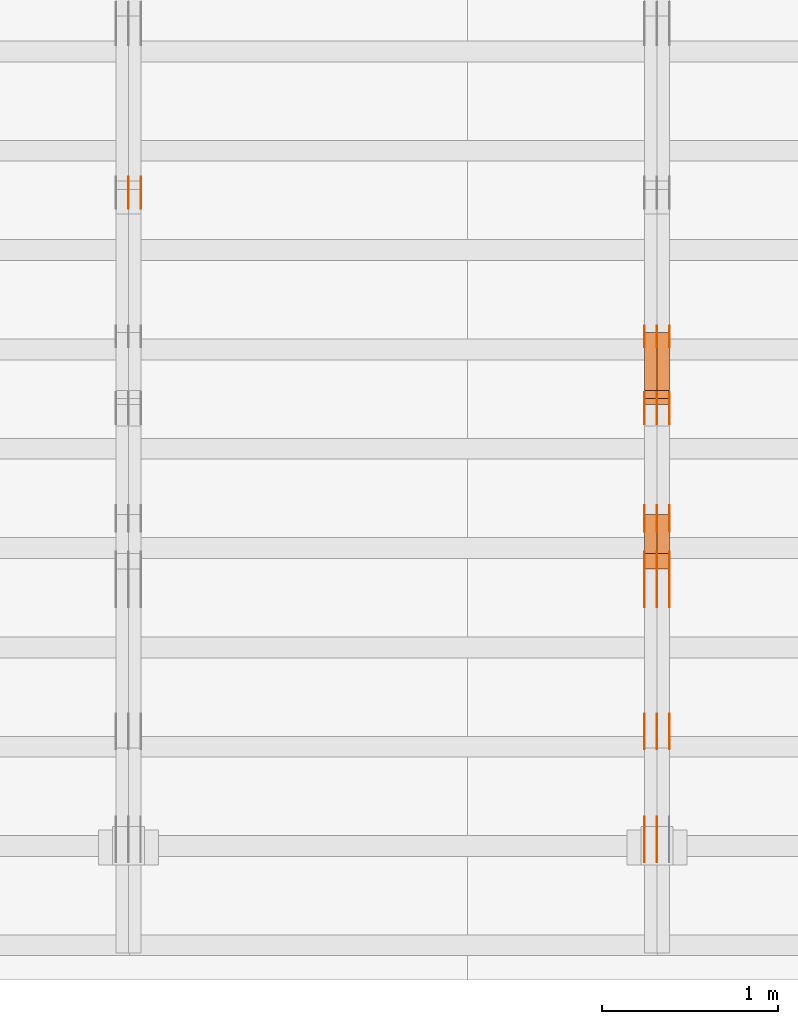
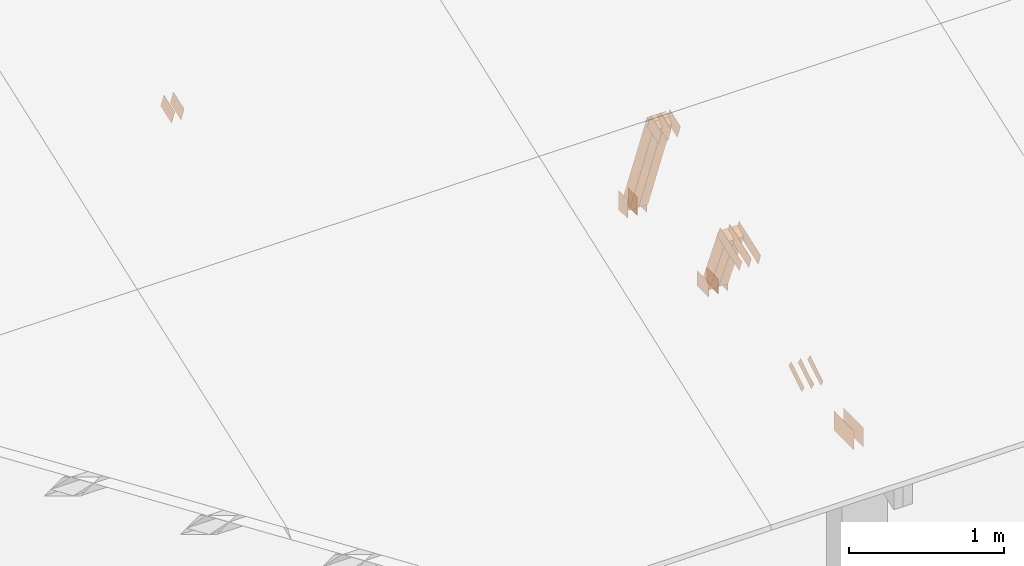
# One storey, part 137 of 189: 29 proxies.
"""IFC2X3 building model written with IfcOpenShell, lengths in millimetres."""

from ifc_helpers import new_model, entity, si_unit, converted_unit, derived_unit, direction, frame, frame_2d, origin, origin_2d_with_axis, place, context, subcontext, project, spatial, polyline, rectangle, outline, extrude, source, transform, mapped, material, type_object, type_shapes, element, save


model = new_model("IFC2X3")

# Units and contexts
model_context = context("Model", 3, precision=0.01, world=origin(), true_north=direction((6.12303176911189e-17, 1.0)))
body_context = subcontext(model_context, "Body", "Model", "MODEL_VIEW")
ifc_project = project(units=[si_unit("LENGTHUNIT", "METRE", prefix="MILLI"), si_unit("AREAUNIT", "SQUARE_METRE"), si_unit("VOLUMEUNIT", "CUBIC_METRE"), converted_unit("PLANEANGLEUNIT", "DEGREE", entity("IfcRatioMeasure", 0.0174532925199433), si_unit("PLANEANGLEUNIT", "RADIAN"), dimensions=[0, 0, 0, 0, 0, 0, 0]), si_unit("MASSUNIT", "GRAM", prefix="KILO"), derived_unit("MASSDENSITYUNIT", [(si_unit("MASSUNIT", "GRAM", prefix="KILO"), 1), (si_unit("LENGTHUNIT", "METRE"), -3)]), si_unit("TIMEUNIT", "SECOND"), si_unit("FREQUENCYUNIT", "HERTZ"), si_unit("THERMODYNAMICTEMPERATUREUNIT", "DEGREE_CELSIUS"), derived_unit("THERMALTRANSMITTANCEUNIT", [(si_unit("MASSUNIT", "GRAM", prefix="KILO"), 1), (si_unit("THERMODYNAMICTEMPERATUREUNIT", "KELVIN"), -1), (si_unit("TIMEUNIT", "SECOND"), -3)]), derived_unit("VOLUMETRICFLOWRATEUNIT", [(si_unit("LENGTHUNIT", "METRE"), 3), (si_unit("TIMEUNIT", "SECOND"), -1)]), si_unit("ELECTRICCURRENTUNIT", "AMPERE"), si_unit("ELECTRICVOLTAGEUNIT", "VOLT"), si_unit("POWERUNIT", "WATT"), si_unit("FORCEUNIT", "NEWTON"), si_unit("ILLUMINANCEUNIT", "LUX"), si_unit("LUMINOUSFLUXUNIT", "LUMEN"), si_unit("LUMINOUSINTENSITYUNIT", "CANDELA"), derived_unit("USERDEFINED", [(si_unit("MASSUNIT", "GRAM", prefix="KILO"), -1), (si_unit("LENGTHUNIT", "METRE"), -2), (si_unit("TIMEUNIT", "SECOND"), 3), (si_unit("LUMINOUSFLUXUNIT", "LUMEN"), 1)]), derived_unit("LINEARVELOCITYUNIT", [(si_unit("LENGTHUNIT", "METRE"), 1), (si_unit("TIMEUNIT", "SECOND"), -1)]), si_unit("PRESSUREUNIT", "PASCAL"), derived_unit("USERDEFINED", [(si_unit("LENGTHUNIT", "METRE"), -2), (si_unit("MASSUNIT", "GRAM", prefix="KILO"), 1), (si_unit("TIMEUNIT", "SECOND"), -2)])], contexts=[model_context])

# Site, building, storey
site_placement = place(None, origin())
site = spatial("IfcSite", under=ifc_project, at=site_placement, CompositionType="ELEMENT")
building_placement = place(site_placement, origin())
building = spatial("IfcBuilding", under=site, at=building_placement, CompositionType="ELEMENT")
storey_placement = place(building_placement, origin())
storey = spatial("IfcBuildingStorey", under=building, at=storey_placement, Name="Default", CompositionType="ELEMENT", Elevation=0.0)

# Proxies
ifc_material_1 = material(Name="IfcSurfaceStyle #199850")
building_element_proxy_type_1 = type_object("IfcBuildingElementProxyType", PredefinedType="NOTDEFINED", material=ifc_material_1)
shared_shape_1 = source(origin(), body_context, "Body", "SweptSolid", [
    extrude(rectangle(XDim=150.0, YDim=120.0, at=frame_2d((1.4210854715202e-14, -7.105427357601e-15), x_axis=(1.0, 0.0))), frame((75.0, 60.0004961323721, 0.0), z_axis=(0.0, 0.0, 1.0), x_axis=(-1.0, 0.0, 0.0)), (0.0, 0.0, 1.0), 1.3),
])
type_shapes(building_element_proxy_type_1, [shared_shape_1])
proxy_1_placement = place(building_placement, frame((36301.3, 2940.99169136763, 170.0), z_axis=(-1.0, 0.0, 0.0), x_axis=(0.0, 0.0, 1.0)))
element("IfcBuildingElementProxy", 1, at=proxy_1_placement, inside=storey, type_object=building_element_proxy_type_1, material=ifc_material_1, context=body_context, shape_type="MappedRepresentation", body=[
    mapped(shared_shape_1, transform((0.0, 0.0, 0.0), scale=1.0)),
])
ifc_material_2 = material(Name="IfcSurfaceStyle #199793")
building_element_proxy_type_2 = type_object("IfcBuildingElementProxyType", PredefinedType="NOTDEFINED", material=ifc_material_2)
shared_shape_2 = source(origin(), body_context, "Body", "SweptSolid", [
    extrude(rectangle(XDim=150.0, YDim=120.0, at=frame_2d((1.4210854715202e-14, -7.105427357601e-15), x_axis=(1.0, 0.0))), frame((75.0, 60.0004961323721, 0.0), z_axis=(0.0, 0.0, 1.0), x_axis=(-1.0, 0.0, 0.0)), (0.0, 0.0, 1.0), 1.29999999999999),
])
type_shapes(building_element_proxy_type_2, [shared_shape_2])
proxy_2_placement = place(building_placement, frame((36230.0, 2940.99169136763, 170.0), z_axis=(-1.0, 0.0, 0.0), x_axis=(0.0, 0.0, 1.0)))
element("IfcBuildingElementProxy", 2, at=proxy_2_placement, inside=storey, type_object=building_element_proxy_type_2, material=ifc_material_2, context=body_context, shape_type="MappedRepresentation", body=[
    mapped(shared_shape_2, transform((0.0, 0.0, 0.0), scale=1.0)),
])
ifc_material_3 = material(Name="IfcSurfaceStyle #199736")
building_element_proxy_type_3 = type_object("IfcBuildingElementProxyType", PredefinedType="NOTDEFINED", material=ifc_material_3)
shared_shape_3 = source(origin(), body_context, "Body", "SweptSolid", [
    extrude(rectangle(XDim=150.0, YDim=120.0, at=frame_2d((1.4210854715202e-14, -7.105427357601e-15), x_axis=(1.0, 0.0))), frame((75.0, 60.0004961323721, 0.0), z_axis=(0.0, 0.0, 1.0), x_axis=(-1.0, 0.0, 0.0)), (0.0, 0.0, 1.0), 1.29999999999999),
])
type_shapes(building_element_proxy_type_3, [shared_shape_3])
proxy_3_placement = place(building_placement, frame((36231.3, 2940.99169136763, 170.0), z_axis=(-1.0, 0.0, 0.0), x_axis=(0.0, 0.0, 1.0)))
element("IfcBuildingElementProxy", 3, at=proxy_3_placement, inside=storey, type_object=building_element_proxy_type_3, material=ifc_material_3, context=body_context, shape_type="MappedRepresentation", body=[
    mapped(shared_shape_3, transform((0.0, 0.0, 0.0), scale=1.0)),
])
ifc_material_4 = material(Name="IfcSurfaceStyle #199679")
building_element_proxy_type_4 = type_object("IfcBuildingElementProxyType", PredefinedType="NOTDEFINED", material=ifc_material_4)
shared_shape_4 = source(origin(), body_context, "Body", "SweptSolid", [
    extrude(rectangle(XDim=150.0, YDim=120.0, at=frame_2d((1.4210854715202e-14, -7.105427357601e-15), x_axis=(1.0, 0.0))), frame((75.0, 60.0004961323721, 0.0), z_axis=(0.0, 0.0, 1.0), x_axis=(-1.0, 0.0, 0.0)), (0.0, 0.0, 1.0), 1.29999999999999),
])
type_shapes(building_element_proxy_type_4, [shared_shape_4])
proxy_4_placement = place(building_placement, frame((36160.0, 2940.99169136763, 170.0), z_axis=(-1.0, 0.0, 0.0), x_axis=(0.0, 0.0, 1.0)))
element("IfcBuildingElementProxy", 4, at=proxy_4_placement, inside=storey, type_object=building_element_proxy_type_4, material=ifc_material_4, context=body_context, shape_type="MappedRepresentation", body=[
    mapped(shared_shape_4, transform((0.0, 0.0, 0.0), scale=1.0)),
])
ifc_material_5 = material(Name="IfcSurfaceStyle #199622")
building_element_proxy_type_5 = type_object("IfcBuildingElementProxyType", PredefinedType="NOTDEFINED", material=ifc_material_5)
shared_shape_5 = source(origin(), body_context, "Body", "SweptSolid", [
    extrude(outline(polyline([(-75.0008071857483, -59.9999039432187), (75.0002916555677, -59.9999039432187), (75.0008280609982, 59.9999039432187), (-75.0003125308176, 59.9999039432187), (-75.0008071857483, -59.9999039432187)])), frame((75.0008280609982, 60.0002349219685, 0.0), z_axis=(0.0, 0.0, 1.0), x_axis=(-1.0, 0.0, 0.0)), (0.0, 0.0, 1.0), 1.3),
])
type_shapes(building_element_proxy_type_5, [shared_shape_5])
proxy_5_placement = place(building_placement, frame((36301.3, 2502.466796875, 1113.95080566406), z_axis=(-1.0, 0.0, 0.0), x_axis=(0.0, 0.939692620785908, 0.342020143325669)))
element("IfcBuildingElementProxy", 5, at=proxy_5_placement, inside=storey, type_object=building_element_proxy_type_5, material=ifc_material_5, context=body_context, shape_type="MappedRepresentation", body=[
    mapped(shared_shape_5, transform((0.0, 0.0, 0.0), scale=1.0)),
])
ifc_material_6 = material(Name="IfcSurfaceStyle #199565")
building_element_proxy_type_6 = type_object("IfcBuildingElementProxyType", PredefinedType="NOTDEFINED", material=ifc_material_6)
shared_shape_6 = source(origin(), body_context, "Body", "SweptSolid", [
    extrude(outline(polyline([(-75.0008071857483, -59.9999039432187), (75.0002916555677, -59.9999039432187), (75.0008280609982, 59.9999039432187), (-75.0003125308176, 59.9999039432187), (-75.0008071857483, -59.9999039432187)])), frame((75.0008280609982, 60.0002349219685, 0.0), z_axis=(0.0, 0.0, 1.0), x_axis=(-1.0, 0.0, 0.0)), (0.0, 0.0, 1.0), 1.29999999999999),
])
type_shapes(building_element_proxy_type_6, [shared_shape_6])
proxy_6_placement = place(building_placement, frame((36230.0, 2502.466796875, 1113.95080566406), z_axis=(-1.0, 0.0, 0.0), x_axis=(0.0, 0.939692620785908, 0.342020143325669)))
element("IfcBuildingElementProxy", 6, at=proxy_6_placement, inside=storey, type_object=building_element_proxy_type_6, material=ifc_material_6, context=body_context, shape_type="MappedRepresentation", body=[
    mapped(shared_shape_6, transform((0.0, 0.0, 0.0), scale=1.0)),
])
ifc_material_7 = material(Name="IfcSurfaceStyle #199508")
building_element_proxy_type_7 = type_object("IfcBuildingElementProxyType", PredefinedType="NOTDEFINED", material=ifc_material_7)
shared_shape_7 = source(origin(), body_context, "Body", "SweptSolid", [
    extrude(outline(polyline([(-75.0008071857483, -59.9999039432187), (75.0002916555677, -59.9999039432187), (75.0008280609982, 59.9999039432187), (-75.0003125308176, 59.9999039432187), (-75.0008071857483, -59.9999039432187)])), frame((75.0008280609982, 60.0002349219685, 0.0), z_axis=(0.0, 0.0, 1.0), x_axis=(-1.0, 0.0, 0.0)), (0.0, 0.0, 1.0), 1.29999999999999),
])
type_shapes(building_element_proxy_type_7, [shared_shape_7])
proxy_7_placement = place(building_placement, frame((36231.3, 2502.466796875, 1113.95080566406), z_axis=(-1.0, 0.0, 0.0), x_axis=(0.0, 0.939692620785908, 0.342020143325669)))
element("IfcBuildingElementProxy", 7, at=proxy_7_placement, inside=storey, type_object=building_element_proxy_type_7, material=ifc_material_7, context=body_context, shape_type="MappedRepresentation", body=[
    mapped(shared_shape_7, transform((0.0, 0.0, 0.0), scale=1.0)),
])
ifc_material_8 = material(Name="IfcSurfaceStyle #199451")
building_element_proxy_type_8 = type_object("IfcBuildingElementProxyType", PredefinedType="NOTDEFINED", material=ifc_material_8)
shared_shape_8 = source(origin(), body_context, "Body", "SweptSolid", [
    extrude(outline(polyline([(-75.0008071857483, -59.9999039432187), (75.0002916555677, -59.9999039432187), (75.0008280609982, 59.9999039432187), (-75.0003125308176, 59.9999039432187), (-75.0008071857483, -59.9999039432187)])), frame((75.0008280609982, 60.0002349219685, 0.0), z_axis=(0.0, 0.0, 1.0), x_axis=(-1.0, 0.0, 0.0)), (0.0, 0.0, 1.0), 1.29999999999999),
])
type_shapes(building_element_proxy_type_8, [shared_shape_8])
proxy_8_placement = place(building_placement, frame((36160.0, 2502.466796875, 1113.95080566406), z_axis=(-1.0, 0.0, 0.0), x_axis=(0.0, 0.939692620785908, 0.342020143325669)))
element("IfcBuildingElementProxy", 8, at=proxy_8_placement, inside=storey, type_object=building_element_proxy_type_8, material=ifc_material_8, context=body_context, shape_type="MappedRepresentation", body=[
    mapped(shared_shape_8, transform((0.0, 0.0, 0.0), scale=1.0)),
])
ifc_material_9 = material(Name="IfcSurfaceStyle #198938")
building_element_proxy_type_9 = type_object("IfcBuildingElementProxyType", PredefinedType="NOTDEFINED", material=ifc_material_9)
shared_shape_9 = source(origin(), body_context, "Body", "SweptSolid", [
    extrude(rectangle(XDim=150.0, YDim=120.0, at=origin_2d_with_axis()), frame((75.0004757715869, 60.0, 0.0), z_axis=(0.0, 0.0, 1.0), x_axis=(-1.0, 0.0, 0.0)), (0.0, 0.0, 1.0), 1.3),
])
type_shapes(building_element_proxy_type_9, [shared_shape_9])
proxy_9_placement = place(building_placement, frame((36301.3, 1892.68702422841, 305.0), z_axis=(-1.0, 0.0, 0.0), x_axis=(0.0, 1.0, 0.0)))
element("IfcBuildingElementProxy", 9, at=proxy_9_placement, inside=storey, type_object=building_element_proxy_type_9, material=ifc_material_9, context=body_context, shape_type="MappedRepresentation", body=[
    mapped(shared_shape_9, transform((0.0, 0.0, 0.0), scale=1.0)),
])
ifc_material_10 = material(Name="IfcSurfaceStyle #198881")
building_element_proxy_type_10 = type_object("IfcBuildingElementProxyType", PredefinedType="NOTDEFINED", material=ifc_material_10)
shared_shape_10 = source(origin(), body_context, "Body", "SweptSolid", [
    extrude(rectangle(XDim=150.0, YDim=120.0, at=origin_2d_with_axis()), frame((75.0004757715869, 60.0, 0.0), z_axis=(0.0, 0.0, 1.0), x_axis=(-1.0, 0.0, 0.0)), (0.0, 0.0, 1.0), 1.29999999999999),
])
type_shapes(building_element_proxy_type_10, [shared_shape_10])
proxy_10_placement = place(building_placement, frame((36230.0, 1892.68702422841, 305.0), z_axis=(-1.0, 0.0, 0.0), x_axis=(0.0, 1.0, 0.0)))
element("IfcBuildingElementProxy", 10, at=proxy_10_placement, inside=storey, type_object=building_element_proxy_type_10, material=ifc_material_10, context=body_context, shape_type="MappedRepresentation", body=[
    mapped(shared_shape_10, transform((0.0, 0.0, 0.0), scale=1.0)),
])
ifc_material_11 = material(Name="IfcSurfaceStyle #198824")
building_element_proxy_type_11 = type_object("IfcBuildingElementProxyType", PredefinedType="NOTDEFINED", material=ifc_material_11)
shared_shape_11 = source(origin(), body_context, "Body", "SweptSolid", [
    extrude(rectangle(XDim=150.0, YDim=120.0, at=origin_2d_with_axis()), frame((75.0004757715869, 60.0, 0.0), z_axis=(0.0, 0.0, 1.0), x_axis=(-1.0, 0.0, 0.0)), (0.0, 0.0, 1.0), 1.29999999999999),
])
type_shapes(building_element_proxy_type_11, [shared_shape_11])
proxy_11_placement = place(building_placement, frame((36231.3, 1892.68702422841, 305.0), z_axis=(-1.0, 0.0, 0.0), x_axis=(0.0, 1.0, 0.0)))
element("IfcBuildingElementProxy", 11, at=proxy_11_placement, inside=storey, type_object=building_element_proxy_type_11, material=ifc_material_11, context=body_context, shape_type="MappedRepresentation", body=[
    mapped(shared_shape_11, transform((0.0, 0.0, 0.0), scale=1.0)),
])
ifc_material_12 = material(Name="IfcSurfaceStyle #198767")
building_element_proxy_type_12 = type_object("IfcBuildingElementProxyType", PredefinedType="NOTDEFINED", material=ifc_material_12)
shared_shape_12 = source(origin(), body_context, "Body", "SweptSolid", [
    extrude(rectangle(XDim=150.0, YDim=120.0, at=origin_2d_with_axis()), frame((75.0004757715869, 60.0, 0.0), z_axis=(0.0, 0.0, 1.0), x_axis=(-1.0, 0.0, 0.0)), (0.0, 0.0, 1.0), 1.29999999999999),
])
type_shapes(building_element_proxy_type_12, [shared_shape_12])
proxy_12_placement = place(building_placement, frame((36160.0, 1892.68702422841, 305.0), z_axis=(-1.0, 0.0, 0.0), x_axis=(0.0, 1.0, 0.0)))
element("IfcBuildingElementProxy", 12, at=proxy_12_placement, inside=storey, type_object=building_element_proxy_type_12, material=ifc_material_12, context=body_context, shape_type="MappedRepresentation", body=[
    mapped(shared_shape_12, transform((0.0, 0.0, 0.0), scale=1.0)),
])
ifc_material_13 = material(Name="IfcSurfaceStyle #198710")
building_element_proxy_type_13 = type_object("IfcBuildingElementProxyType", PredefinedType="NOTDEFINED", material=ifc_material_13)
shared_shape_13 = source(origin(), body_context, "Body", "SweptSolid", [
    extrude(outline(polyline([(-150.000217420008, -47.9999344162752), (150.000165800718, -47.9999344162752), (150.000227857633, 47.9999344162752), (-150.000176238343, 47.9999344162752), (-150.000217420008, -47.9999344162752)])), frame((150.000227857633, 48.0000430742566, 0.0), z_axis=(0.0, 0.0, 1.0), x_axis=(-1.0, 0.0, 0.0)), (0.0, 0.0, 1.0), 1.29999999999999),
])
type_shapes(building_element_proxy_type_13, [shared_shape_13])
proxy_13_placement = place(building_placement, frame((36301.3, 1464.46484375, 723.378723144533), z_axis=(-1.0, 0.0, 0.0), x_axis=(0.0, 0.939692620785908, 0.342020143325669)))
element("IfcBuildingElementProxy", 13, at=proxy_13_placement, inside=storey, type_object=building_element_proxy_type_13, material=ifc_material_13, context=body_context, shape_type="MappedRepresentation", body=[
    mapped(shared_shape_13, transform((0.0, 0.0, 0.0), scale=1.0)),
])
ifc_material_14 = material(Name="IfcSurfaceStyle #198653")
building_element_proxy_type_14 = type_object("IfcBuildingElementProxyType", PredefinedType="NOTDEFINED", material=ifc_material_14)
shared_shape_14 = source(origin(), body_context, "Body", "SweptSolid", [
    extrude(outline(polyline([(-150.000217420008, -47.9999344162752), (150.000165800718, -47.9999344162752), (150.000227857633, 47.9999344162752), (-150.000176238343, 47.9999344162752), (-150.000217420008, -47.9999344162752)])), frame((150.000227857633, 48.0000430742566, 0.0), z_axis=(0.0, 0.0, 1.0), x_axis=(-1.0, 0.0, 0.0)), (0.0, 0.0, 1.0), 1.29999999999998),
])
type_shapes(building_element_proxy_type_14, [shared_shape_14])
proxy_14_placement = place(building_placement, frame((36230.0, 1464.46484375, 723.378723144533), z_axis=(-1.0, 0.0, 0.0), x_axis=(0.0, 0.939692620785908, 0.342020143325669)))
element("IfcBuildingElementProxy", 14, at=proxy_14_placement, inside=storey, type_object=building_element_proxy_type_14, material=ifc_material_14, context=body_context, shape_type="MappedRepresentation", body=[
    mapped(shared_shape_14, transform((0.0, 0.0, 0.0), scale=1.0)),
])
ifc_material_15 = material(Name="IfcSurfaceStyle #198596")
building_element_proxy_type_15 = type_object("IfcBuildingElementProxyType", PredefinedType="NOTDEFINED", material=ifc_material_15)
shared_shape_15 = source(origin(), body_context, "Body", "SweptSolid", [
    extrude(outline(polyline([(-150.000217420008, -47.9999344162752), (150.000165800718, -47.9999344162752), (150.000227857633, 47.9999344162752), (-150.000176238343, 47.9999344162752), (-150.000217420008, -47.9999344162752)])), frame((150.000227857633, 48.0000430742566, 0.0), z_axis=(0.0, 0.0, 1.0), x_axis=(-1.0, 0.0, 0.0)), (0.0, 0.0, 1.0), 1.29999999999998),
])
type_shapes(building_element_proxy_type_15, [shared_shape_15])
proxy_15_placement = place(building_placement, frame((36231.3, 1464.46484375, 723.378723144533), z_axis=(-1.0, 0.0, 0.0), x_axis=(0.0, 0.939692620785908, 0.342020143325669)))
element("IfcBuildingElementProxy", 15, at=proxy_15_placement, inside=storey, type_object=building_element_proxy_type_15, material=ifc_material_15, context=body_context, shape_type="MappedRepresentation", body=[
    mapped(shared_shape_15, transform((0.0, 0.0, 0.0), scale=1.0)),
])
ifc_material_16 = material(Name="IfcSurfaceStyle #198539")
building_element_proxy_type_16 = type_object("IfcBuildingElementProxyType", PredefinedType="NOTDEFINED", material=ifc_material_16)
shared_shape_16 = source(origin(), body_context, "Body", "SweptSolid", [
    extrude(outline(polyline([(-150.000217420008, -47.9999344162752), (150.000165800718, -47.9999344162752), (150.000227857633, 47.9999344162752), (-150.000176238343, 47.9999344162752), (-150.000217420008, -47.9999344162752)])), frame((150.000227857633, 48.0000430742566, 0.0), z_axis=(0.0, 0.0, 1.0), x_axis=(-1.0, 0.0, 0.0)), (0.0, 0.0, 1.0), 1.29999999999998),
])
type_shapes(building_element_proxy_type_16, [shared_shape_16])
proxy_16_placement = place(building_placement, frame((36160.0, 1464.46484375, 723.378723144533), z_axis=(-1.0, 0.0, 0.0), x_axis=(0.0, 0.939692620785908, 0.342020143325669)))
element("IfcBuildingElementProxy", 16, at=proxy_16_placement, inside=storey, type_object=building_element_proxy_type_16, material=ifc_material_16, context=body_context, shape_type="MappedRepresentation", body=[
    mapped(shared_shape_16, transform((0.0, 0.0, 0.0), scale=1.0)),
])
ifc_material_17 = material(Name="IfcSurfaceStyle #198026")
building_element_proxy_type_17 = type_object("IfcBuildingElementProxyType", PredefinedType="NOTDEFINED", material=ifc_material_17)
shared_shape_17 = source(origin(), body_context, "Body", "SweptSolid", [
    extrude(outline(polyline([(-100.000388510424, -29.9995882393532), (100.000691805256, -29.9995882393532), (100.000392424258, 29.9995882393532), (-100.00069571909, 29.9995882393532), (-100.000388510424, -29.9995882393532)])), frame((100.000691805256, 30.0002299338894, 0.0), z_axis=(0.0, 0.0, 1.0), x_axis=(-1.0, 0.0, 0.0)), (0.0, 0.0, 1.0), 1.3),
])
type_shapes(building_element_proxy_type_17, [shared_shape_17])
proxy_17_placement = place(building_placement, frame((36301.3, 656.945055513712, 219.45219322107), z_axis=(-1.0, 0.0, 0.0), x_axis=(0.0, 0.858392121304013, 0.51299411895576)))
element("IfcBuildingElementProxy", 17, at=proxy_17_placement, inside=storey, type_object=building_element_proxy_type_17, material=ifc_material_17, context=body_context, shape_type="MappedRepresentation", body=[
    mapped(shared_shape_17, transform((0.0, 0.0, 0.0), scale=1.0)),
])
ifc_material_18 = material(Name="IfcSurfaceStyle #197969")
building_element_proxy_type_18 = type_object("IfcBuildingElementProxyType", PredefinedType="NOTDEFINED", material=ifc_material_18)
shared_shape_18 = source(origin(), body_context, "Body", "SweptSolid", [
    extrude(outline(polyline([(-100.000388510424, -29.9995882393532), (100.000691805256, -29.9995882393532), (100.000392424258, 29.9995882393532), (-100.00069571909, 29.9995882393532), (-100.000388510424, -29.9995882393532)])), frame((100.000691805256, 30.0002299338894, 0.0), z_axis=(0.0, 0.0, 1.0), x_axis=(-1.0, 0.0, 0.0)), (0.0, 0.0, 1.0), 1.29999999999998),
])
type_shapes(building_element_proxy_type_18, [shared_shape_18])
proxy_18_placement = place(building_placement, frame((36230.0, 656.945055513712, 219.45219322107), z_axis=(-1.0, 0.0, 0.0), x_axis=(0.0, 0.858392121304013, 0.51299411895576)))
element("IfcBuildingElementProxy", 18, at=proxy_18_placement, inside=storey, type_object=building_element_proxy_type_18, material=ifc_material_18, context=body_context, shape_type="MappedRepresentation", body=[
    mapped(shared_shape_18, transform((0.0, 0.0, 0.0), scale=1.0)),
])
ifc_material_19 = material(Name="IfcSurfaceStyle #197912")
building_element_proxy_type_19 = type_object("IfcBuildingElementProxyType", PredefinedType="NOTDEFINED", material=ifc_material_19)
shared_shape_19 = source(origin(), body_context, "Body", "SweptSolid", [
    extrude(outline(polyline([(-100.000388510424, -29.9995882393532), (100.000691805256, -29.9995882393532), (100.000392424258, 29.9995882393532), (-100.00069571909, 29.9995882393532), (-100.000388510424, -29.9995882393532)])), frame((100.000691805256, 30.0002299338894, 0.0), z_axis=(0.0, 0.0, 1.0), x_axis=(-1.0, 0.0, 0.0)), (0.0, 0.0, 1.0), 1.29999999999998),
])
type_shapes(building_element_proxy_type_19, [shared_shape_19])
proxy_19_placement = place(building_placement, frame((36231.3, 656.945055513712, 219.45219322107), z_axis=(-1.0, 0.0, 0.0), x_axis=(0.0, 0.858392121304013, 0.51299411895576)))
element("IfcBuildingElementProxy", 19, at=proxy_19_placement, inside=storey, type_object=building_element_proxy_type_19, material=ifc_material_19, context=body_context, shape_type="MappedRepresentation", body=[
    mapped(shared_shape_19, transform((0.0, 0.0, 0.0), scale=1.0)),
])
ifc_material_20 = material(Name="IfcSurfaceStyle #197855")
building_element_proxy_type_20 = type_object("IfcBuildingElementProxyType", PredefinedType="NOTDEFINED", material=ifc_material_20)
shared_shape_20 = source(origin(), body_context, "Body", "SweptSolid", [
    extrude(outline(polyline([(-100.000388510424, -29.9995882393532), (100.000691805256, -29.9995882393532), (100.000392424258, 29.9995882393532), (-100.00069571909, 29.9995882393532), (-100.000388510424, -29.9995882393532)])), frame((100.000691805256, 30.0002299338894, 0.0), z_axis=(0.0, 0.0, 1.0), x_axis=(-1.0, 0.0, 0.0)), (0.0, 0.0, 1.0), 1.29999999999999),
])
type_shapes(building_element_proxy_type_20, [shared_shape_20])
proxy_20_placement = place(building_placement, frame((36160.0, 656.945055513712, 219.45219322107), z_axis=(-1.0, 0.0, 0.0), x_axis=(0.0, 0.858392121304013, 0.51299411895576)))
element("IfcBuildingElementProxy", 20, at=proxy_20_placement, inside=storey, type_object=building_element_proxy_type_20, material=ifc_material_20, context=body_context, shape_type="MappedRepresentation", body=[
    mapped(shared_shape_20, transform((0.0, 0.0, 0.0), scale=1.0)),
])
ifc_material_21 = material(Name="IfcSurfaceStyle #196376")
building_element_proxy_type_21 = type_object("IfcBuildingElementProxyType", PredefinedType="NOTDEFINED", material=ifc_material_21)
shared_shape_21 = source(origin(), body_context, "Body", "SweptSolid", [
    extrude(rectangle(XDim=258.0, YDim=151.999992370605, at=origin_2d_with_axis()), frame((129.0, 76.0000049445079, 0.0), z_axis=(0.0, 0.0, 1.0), x_axis=(-1.0, 0.0, 0.0)), (0.0, 0.0, 1.0), 0.999999999999984),
])
type_shapes(building_element_proxy_type_21, [shared_shape_21])
proxy_21_placement = place(building_placement, frame((36231.0, 16.236328125, 268.138222870533), z_axis=(-1.0, 0.0, 0.0), x_axis=(0.0, 1.0, 0.0)))
element("IfcBuildingElementProxy", 21, at=proxy_21_placement, inside=storey, type_object=building_element_proxy_type_21, material=ifc_material_21, Name="GNT100S 152x258", context=body_context, shape_type="MappedRepresentation", body=[
    mapped(shared_shape_21, transform((0.0, 0.0, 0.0), scale=1.0)),
])
ifc_material_22 = material(Name="IfcSurfaceStyle #196319")
building_element_proxy_type_22 = type_object("IfcBuildingElementProxyType", PredefinedType="NOTDEFINED", material=ifc_material_22)
shared_shape_22 = source(origin(), body_context, "Body", "SweptSolid", [
    extrude(rectangle(XDim=258.0, YDim=151.999992370605, at=origin_2d_with_axis()), frame((129.0, 76.0000049445079, 0.0), z_axis=(0.0, 0.0, 1.0), x_axis=(-1.0, 0.0, 0.0)), (0.0, 0.0, 1.0), 0.999999999999984),
])
type_shapes(building_element_proxy_type_22, [shared_shape_22])
proxy_22_placement = place(building_placement, frame((36160.0, 16.236328125, 268.138222870533), z_axis=(-1.0, 0.0, 0.0), x_axis=(0.0, 1.0, 0.0)))
element("IfcBuildingElementProxy", 22, at=proxy_22_placement, inside=storey, type_object=building_element_proxy_type_22, material=ifc_material_22, Name="GNT100S 152x258", context=body_context, shape_type="MappedRepresentation", body=[
    mapped(shared_shape_22, transform((0.0, 0.0, 0.0), scale=1.0)),
])
ifc_material_23 = material(Name="IfcSurfaceStyle #192050")
building_element_proxy_type_23 = type_object("IfcBuildingElementProxyType", Name="T1-W14 192048", PredefinedType="NOTDEFINED", material=ifc_material_23)
shared_shape_23 = source(origin(), body_context, "Body", "SweptSolid", [
    extrude(outline(polyline([(-526.068269984593, -47.5004595774917), (341.27769108205, -47.5004595774917), (373.679499344758, 0.000392511719837607), (373.092506900368, 47.5002633216318), (-561.981427342584, 47.5002633216318), (-526.068269984593, -47.5004595774917)])), frame((373.67978783425, 47.5005221796964, 0.0), z_axis=(0.0, 0.0, 1.0), x_axis=(-1.0, 0.0, 0.0)), (0.0, 0.0, 1.0), 69.9999999999999),
])
type_shapes(building_element_proxy_type_23, [shared_shape_23])
proxy_23_placement = place(building_placement, frame((36300.0, 2693.38241954499, 1120.21215048788), z_axis=(-1.0, 0.0, 0.0), x_axis=(0.0, 0.353606472447916, -0.935394281916958)))
element("IfcBuildingElementProxy", 23, at=proxy_23_placement, inside=storey, type_object=building_element_proxy_type_23, material=ifc_material_23, Name="T1-W14", context=body_context, shape_type="MappedRepresentation", body=[
    mapped(shared_shape_23, transform((0.0, 0.0, 0.0), scale=1.0)),
])
ifc_material_24 = material(Name="IfcSurfaceStyle #191984")
building_element_proxy_type_24 = type_object("IfcBuildingElementProxyType", Name="T1-W14 191982", PredefinedType="NOTDEFINED", material=ifc_material_24)
shared_shape_24 = source(origin(), body_context, "Body", "SweptSolid", [
    extrude(outline(polyline([(-526.068269984593, -47.5004595774917), (341.27769108205, -47.5004595774917), (373.679499344758, 0.000392511719837607), (373.092506900368, 47.5002633216318), (-561.981427342584, 47.5002633216318), (-526.068269984593, -47.5004595774917)])), frame((373.67978783425, 47.5005221796964, 0.0), z_axis=(0.0, 0.0, 1.0), x_axis=(-1.0, 0.0, 0.0)), (0.0, 0.0, 1.0), 69.9999999999999),
])
type_shapes(building_element_proxy_type_24, [shared_shape_24])
proxy_24_placement = place(building_placement, frame((36230.0, 2693.38241954499, 1120.21215048788), z_axis=(-1.0, 0.0, 0.0), x_axis=(0.0, 0.353606472447916, -0.935394281916958)))
element("IfcBuildingElementProxy", 24, at=proxy_24_placement, inside=storey, type_object=building_element_proxy_type_24, material=ifc_material_24, Name="T1-W14", context=body_context, shape_type="MappedRepresentation", body=[
    mapped(shared_shape_24, transform((0.0, 0.0, 0.0), scale=1.0)),
])
ifc_material_25 = material(Name="IfcSurfaceStyle #191522")
building_element_proxy_type_25 = type_object("IfcBuildingElementProxyType", Name="T1-W15 191520", PredefinedType="NOTDEFINED", material=ifc_material_25)
shared_shape_25 = source(origin(), body_context, "Body", "SweptSolid", [
    extrude(outline(polyline([(-317.132720418368, -47.5005147440206), (220.445242566881, -47.5005147440206), (227.5021778825, -0.000126286009697951), (225.500088907744, 47.5005778870255), (-356.314788938758, 47.5005778870255), (-317.132720418368, -47.5005147440206)])), frame((227.5021778825, 47.5005778870255, 0.0), z_axis=(0.0, 0.0, 1.0), x_axis=(-1.0, 0.0, 0.0)), (0.0, 0.0, 1.0), 70.0),
])
type_shapes(building_element_proxy_type_25, [shared_shape_25])
proxy_25_placement = place(building_placement, frame((36300.0, 1767.47882447529, 784.714556181707), z_axis=(-1.0, 0.0, 0.0), x_axis=(0.0, 0.381283266795389, -0.924458257825542)))
element("IfcBuildingElementProxy", 25, at=proxy_25_placement, inside=storey, type_object=building_element_proxy_type_25, material=ifc_material_25, Name="T1-W15", context=body_context, shape_type="MappedRepresentation", body=[
    mapped(shared_shape_25, transform((0.0, 0.0, 0.0), scale=1.0)),
])
ifc_material_26 = material(Name="IfcSurfaceStyle #191456")
building_element_proxy_type_26 = type_object("IfcBuildingElementProxyType", Name="T1-W15 191454", PredefinedType="NOTDEFINED", material=ifc_material_26)
shared_shape_26 = source(origin(), body_context, "Body", "SweptSolid", [
    extrude(outline(polyline([(-317.132720418368, -47.5005147440206), (220.445242566881, -47.5005147440206), (227.5021778825, -0.000126286009697951), (225.500088907744, 47.5005778870255), (-356.314788938758, 47.5005778870255), (-317.132720418368, -47.5005147440206)])), frame((227.5021778825, 47.5005778870255, 0.0), z_axis=(0.0, 0.0, 1.0), x_axis=(-1.0, 0.0, 0.0)), (0.0, 0.0, 1.0), 70.0),
])
type_shapes(building_element_proxy_type_26, [shared_shape_26])
proxy_26_placement = place(building_placement, frame((36230.0, 1767.47882447529, 784.714556181707), z_axis=(-1.0, 0.0, 0.0), x_axis=(0.0, 0.381283266795389, -0.924458257825542)))
element("IfcBuildingElementProxy", 26, at=proxy_26_placement, inside=storey, type_object=building_element_proxy_type_26, material=ifc_material_26, Name="T1-W15", context=body_context, shape_type="MappedRepresentation", body=[
    mapped(shared_shape_26, transform((0.0, 0.0, 0.0), scale=1.0)),
])
ifc_material_27 = material(Name="IfcSurfaceStyle #184744")
building_element_proxy_type_27 = type_object("IfcBuildingElementProxyType", PredefinedType="NOTDEFINED", material=ifc_material_27)
shared_shape_27 = source(origin(), body_context, "Body", "SweptSolid", [
    extrude(outline(polyline([(-74.9994515581384, -59.9999039432178), (74.9998536965286, -59.9999039432178), (75.0003483514593, 59.9999039432178), (-75.0007504898495, 59.9999039432178), (-74.9994515581384, -59.9999039432178)])), frame((75.0003483514593, 60.0003496305408, 0.0), z_axis=(0.0, 0.0, 1.0), x_axis=(-1.0, 0.0, 0.0)), (0.0, 0.0, 1.0), 1.3),
])
type_shapes(building_element_proxy_type_27, [shared_shape_27])
proxy_27_placement = place(building_placement, frame((33301.3, 3726.8984375, 1559.607421875), z_axis=(-1.0, 0.0, 0.0), x_axis=(0.0, 0.939692620785908, 0.342020143325669)))
element("IfcBuildingElementProxy", 27, at=proxy_27_placement, inside=storey, type_object=building_element_proxy_type_27, material=ifc_material_27, context=body_context, shape_type="MappedRepresentation", body=[
    mapped(shared_shape_27, transform((0.0, 0.0, 0.0), scale=1.0)),
])
ifc_material_28 = material(Name="IfcSurfaceStyle #184687")
building_element_proxy_type_28 = type_object("IfcBuildingElementProxyType", PredefinedType="NOTDEFINED", material=ifc_material_28)
shared_shape_28 = source(origin(), body_context, "Body", "SweptSolid", [
    extrude(outline(polyline([(-74.9994515581384, -59.9999039432178), (74.9998536965286, -59.9999039432178), (75.0003483514593, 59.9999039432178), (-75.0007504898495, 59.9999039432178), (-74.9994515581384, -59.9999039432178)])), frame((75.0003483514593, 60.0003496305408, 0.0), z_axis=(0.0, 0.0, 1.0), x_axis=(-1.0, 0.0, 0.0)), (0.0, 0.0, 1.0), 1.29999999999999),
])
type_shapes(building_element_proxy_type_28, [shared_shape_28])
proxy_28_placement = place(building_placement, frame((33230.0, 3726.8984375, 1559.607421875), z_axis=(-1.0, 0.0, 0.0), x_axis=(0.0, 0.939692620785908, 0.342020143325669)))
element("IfcBuildingElementProxy", 28, at=proxy_28_placement, inside=storey, type_object=building_element_proxy_type_28, material=ifc_material_28, context=body_context, shape_type="MappedRepresentation", body=[
    mapped(shared_shape_28, transform((0.0, 0.0, 0.0), scale=1.0)),
])
ifc_material_29 = material(Name="IfcSurfaceStyle #184630")
building_element_proxy_type_29 = type_object("IfcBuildingElementProxyType", PredefinedType="NOTDEFINED", material=ifc_material_29)
shared_shape_29 = source(origin(), body_context, "Body", "SweptSolid", [
    extrude(outline(polyline([(-74.9994515581384, -59.9999039432178), (74.9998536965286, -59.9999039432178), (75.0003483514593, 59.9999039432178), (-75.0007504898495, 59.9999039432178), (-74.9994515581384, -59.9999039432178)])), frame((75.0003483514593, 60.0003496305408, 0.0), z_axis=(0.0, 0.0, 1.0), x_axis=(-1.0, 0.0, 0.0)), (0.0, 0.0, 1.0), 1.29999999999999),
])
type_shapes(building_element_proxy_type_29, [shared_shape_29])
proxy_29_placement = place(building_placement, frame((33231.3, 3726.8984375, 1559.607421875), z_axis=(-1.0, 0.0, 0.0), x_axis=(0.0, 0.939692620785908, 0.342020143325669)))
element("IfcBuildingElementProxy", 29, at=proxy_29_placement, inside=storey, type_object=building_element_proxy_type_29, material=ifc_material_29, context=body_context, shape_type="MappedRepresentation", body=[
    mapped(shared_shape_29, transform((0.0, 0.0, 0.0), scale=1.0)),
])

save(model, "model.ifc")
